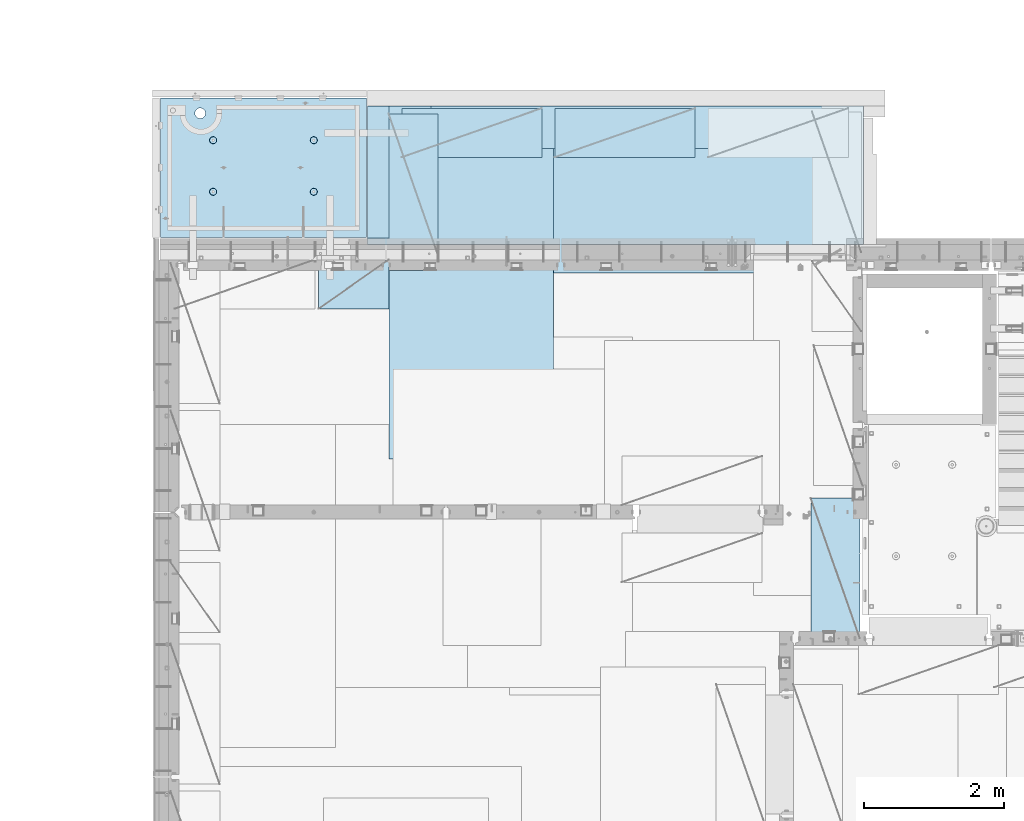
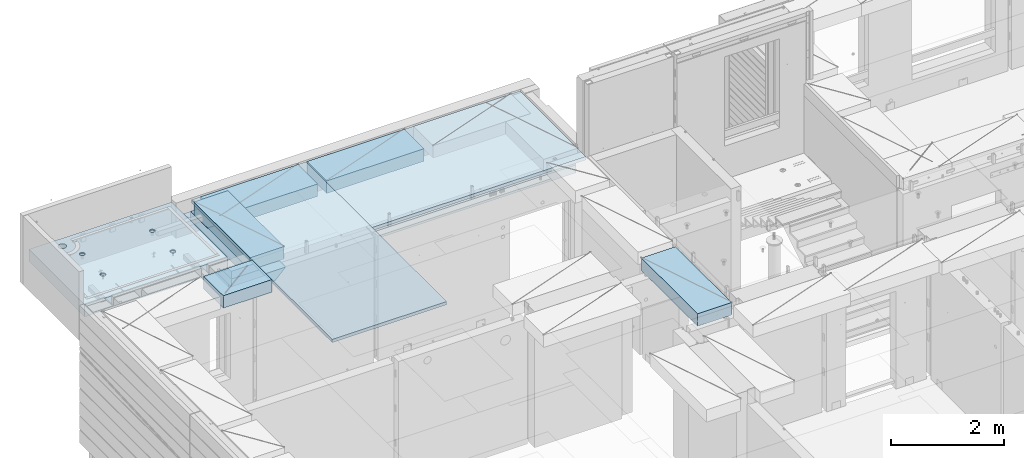
# One storey, part 185 of 325: 10 plates, 3 slabs, 13 elements without a shape of their own.
"""IFC2X3 building model written with IfcOpenShell, lengths in millimetres."""

from ifc_helpers import new_model, si_unit, frame, origin_with_axes, place, context, subcontext, project, spatial, faceted_brep, material, type_object, element, aggregate, save


model = new_model("IFC2X3")

# Units and contexts
model_context = context("Model", 3, precision=1e-05, world=origin_with_axes())
body_context = subcontext(model_context, "Body", "Model", "MODEL_VIEW")
ifc_project = project(units=[si_unit("LENGTHUNIT", "METRE", prefix="MILLI"), si_unit("AREAUNIT", "SQUARE_METRE"), si_unit("VOLUMEUNIT", "CUBIC_METRE"), si_unit("MASSUNIT", "GRAM", prefix="KILO"), si_unit("TIMEUNIT", "SECOND"), si_unit("PLANEANGLEUNIT", "RADIAN"), si_unit("SOLIDANGLEUNIT", "STERADIAN"), si_unit("THERMODYNAMICTEMPERATUREUNIT", "DEGREE_CELSIUS"), si_unit("LUMINOUSINTENSITYUNIT", "LUMEN")], contexts=[model_context])

# Site, building, storey
site_placement = place(None, origin_with_axes())
site = spatial("IfcSite", under=ifc_project, at=site_placement, CompositionType="ELEMENT")
building_placement = place(site_placement, origin_with_axes())
building = spatial("IfcBuilding", under=site, at=building_placement, CompositionType="ELEMENT")
storey_placement = place(building_placement, origin_with_axes())
storey = spatial("IfcBuildingStorey", under=building, at=storey_placement, Name="1", CompositionType="ELEMENT", Elevation=0.0)

# Assembly, slab
assembly_1_placement = place(storey_placement, origin_with_axes())
assembly_1 = element("IfcElementAssembly", 1, at=assembly_1_placement, inside=storey, AssemblyPlace="NOTDEFINED", PredefinedType="REINFORCEMENT_UNIT")
ifc_material_1 = material(Name="CONCRETE/C35/45")
slab_type_1 = type_object("IfcSlabType", PredefinedType="NOTDEFINED")
slab_1_placement = place(assembly_1_placement, frame((7734.99985681325, 20899.9965573523, 84575.0), z_axis=(-2.2639999995273e-06, 0.999999999997437, 0.0), x_axis=(0.999999999997251, 2.34499999952812e-06, 0.0)))
slab_1 = element("IfcSlab", 2, at=slab_1_placement, type_object=slab_type_1, material=ifc_material_1, PredefinedType="FLOOR", context=body_context, shape_type="Brep", body=[
    faceted_brep([(2200.45398600256, -110.0, 1337.44476079497), (2214.39241555253, -110.0, 1344.54670420538), (2225.45402859605, -110.0, 1355.60826537005), (2232.55603737762, -110.0, 1369.54666161175), (2235.0032477951, -110.0, 1384.99750559184), (2232.5561098421, -110.0, 1400.44836104917), (2225.45416643169, -110.0, 1414.38679059914), (2214.39260526702, -110.0, 1425.44840364265), (2200.45420902531, -110.0, 1432.55041242422), (2185.00336504523, -110.0, 1434.9976228417), (2169.55250958791, -110.0, 1432.55048488871), (2155.61408003793, -110.0, 1425.44854147829), (2144.55246699442, -110.0, 1414.38698031362), (2137.45045821285, -110.0, 1400.44858407192), (2135.00324779537, -110.0, 1384.99774009184), (2137.45038574836, -110.0, 1369.54688463451), (2144.55232915878, -110.0, 1355.60845508454), (2155.61389032345, -110.0, 1344.54684204102), (2169.55228656515, -110.0, 1337.44483325945), (2185.00313054523, -110.0, 1334.99762284198), (2226.41728354208, -130.0, 1415.08653268859), (2233.68832084322, -130.0, 1400.81623576839), (2215.09235187349, -130.0, 1426.41151747124), (2200.8220890546, -130.0, 1433.68262169999), (2185.0033678369, -130.0, 1436.18809903217), (2169.18463486868, -130.0, 1433.68269588982), (2154.91433794847, -130.0, 1426.41165858869), (2143.58935316583, -130.0, 1415.08672692009), (2136.31824893708, -130.0, 1400.81646410121), (2133.8127716049, -130.0, 1384.9977428835), (2136.31817474725, -130.0, 1369.17900991529), (2143.58921204838, -130.0, 1354.90871299508), (2154.91414371698, -130.0, 1343.58372821243), (2169.18440653586, -130.0, 1336.31262398369), (2185.00312775357, -130.0, 1333.8071466515), (2200.82186072178, -130.0, 1336.31254979386), (2215.09215764199, -130.0, 1343.58358709499), (2226.41714242464, -130.0, 1354.90851876358), (2233.68824665339, -130.0, 1369.17878158247), (2236.19372398557, -130.0, 1384.99750280017), (765.453986006505, -110.0, 1337.44812586997), (779.392415556478, -110.0, 1344.55006928038), (790.454028599992, -110.0, 1355.61163044505), (797.556037381562, -110.0, 1369.55002668675), (800.003247799041, -110.0, 1385.00087066684), (797.556109846048, -110.0, 1400.45172612417), (790.454166435635, -110.0, 1414.39015567414), (779.392605270965, -110.0, 1425.45176871765), (765.45420902926, -110.0, 1432.55377749922), (750.003365049179, -110.0, 1435.0009879167), (734.552509591851, -110.0, 1432.55384996371), (720.614080041878, -110.0, 1425.4519065533), (709.552466998364, -110.0, 1414.39034538862), (702.450458216794, -110.0, 1400.45194914692), (700.003247799315, -110.0, 1385.00110516684), (702.450385752309, -110.0, 1369.5502497095), (709.552329162721, -110.0, 1355.61182015954), (720.613890327391, -110.0, 1344.55020711602), (734.552286569096, -110.0, 1337.44819833446), (750.003130549179, -110.0, 1335.00098791698), (798.688320847163, -130.0, 1400.81960084339), (801.193723989514, -130.0, 1385.00086787517), (791.417283546027, -130.0, 1415.0898977636), (780.092351877434, -130.0, 1426.41488254624), (765.822089058547, -130.0, 1433.68598677499), (750.003367840845, -130.0, 1436.19146410717), (734.184634872629, -130.0, 1433.68606096482), (719.914337952418, -130.0, 1426.41502366369), (708.589353169771, -130.0, 1415.09009199509), (701.318248941023, -130.0, 1400.81982917621), (698.812771608842, -130.0, 1385.00110795851), (701.318174751194, -130.0, 1369.18237499029), (708.589212052329, -130.0, 1354.91207807008), (719.914143720922, -130.0, 1343.58709328743), (734.184406539811, -130.0, 1336.31598905868), (750.003127757513, -130.0, 1333.8105117265), (765.821860725729, -130.0, 1336.31591486885), (780.092157645939, -130.0, 1343.58695216999), (791.417142428585, -130.0, 1354.91188383858), (798.688246657333, -130.0, 1369.18214665747), (2935.0, -130.0, 1.16051523946226e-09), (0.0, -130.0, -3.63797880709171e-12), (0.0, 130.0, -1.81898940354586e-12), (2935.0, 130.0, 1.16051523946226e-09), (2935.00146484375, -130.0, 1985.00366210938), (2935.00146484375, 130.0, 1985.00366210938), (0.00127768016045593, -130.0, 1985.00366210937), (0.00127768016045593, 130.0, 1985.00366210937), (629.955082303701, 130.0, 1807.51685424544), (618.036222033796, 130.0, 1823.04989078421), (602.503241394663, 130.0, 1834.96882390392), (584.414687347387, 130.0, 1842.46139800945), (565.003264957546, 130.0, 1845.01700655756), (545.591830582116, 130.0, 1842.46148904905), (527.503241394868, 130.0, 1834.96899977892), (511.970204856105, 130.0, 1823.05013950902), (500.051271736391, 130.0, 1807.51715886988), (492.558697630866, 130.0, 1789.42860482261), (490.003089082753, 130.0, 1770.01718243277), (492.558606591267, 130.0, 1750.60574805734), (500.05109586139, 130.0, 1732.51715887009), (511.969956131295, 130.0, 1716.98412233133), (527.502936770432, 130.0, 1705.06518921161), (545.591490817707, 130.0, 1697.57261510608), (565.002913207545, 130.0, 1695.01700655797), (584.414347582979, 130.0, 1697.57252406649), (602.502936770226, 130.0, 1705.06501333661), (618.035973308986, 130.0, 1716.98387360652), (629.9549064287, 130.0, 1732.51685424565), (637.447480534229, 130.0, 1750.60540829293), (640.00308908234, 130.0, 1770.01683068277), (637.447571573828, 130.0, 1789.4282650582), (637.447571573828, -130.0, 1789.4282650582), (640.00308908234, -130.0, 1770.01683068277), (629.955082303701, -130.0, 1807.51685424544), (618.036222033796, -130.0, 1823.04989078421), (602.503241394663, -130.0, 1834.96882390392), (584.414687347387, -130.0, 1842.46139800945), (565.003264957546, -130.0, 1845.01700655756), (545.591830582116, -130.0, 1842.46148904905), (527.503241394868, -130.0, 1834.96899977892), (511.970204856105, -130.0, 1823.05013950902), (500.051271736391, -130.0, 1807.51715886988), (492.558697630866, -130.0, 1789.42860482261), (490.003089082753, -130.0, 1770.01718243277), (492.558606591267, -130.0, 1750.60574805734), (500.05109586139, -130.0, 1732.51715887009), (511.969956131295, -130.0, 1716.98412233133), (527.502936770432, -130.0, 1705.06518921161), (545.591490817707, -130.0, 1697.57261510608), (565.002913207545, -130.0, 1695.01700655797), (584.414347582979, -130.0, 1697.57252406649), (602.502936770226, -130.0, 1705.06501333661), (618.035973308986, -130.0, 1716.98387360652), (629.9549064287, -130.0, 1732.51685424565), (637.447480534229, -130.0, 1750.60540829293), (765.452262510529, -110.0, 602.446294854952), (779.390692060502, -110.0, 609.548238265361), (790.452305104016, -110.0, 620.609799430033), (797.554313885586, -110.0, 634.548195671738), (800.001524303065, -110.0, 649.999039651819), (797.554386350072, -110.0, 665.449895109152), (790.452442939657, -110.0, 679.388324659118), (779.390881774987, -110.0, 690.449937702637), (765.452485533282, -110.0, 697.551946484204), (750.001641553203, -110.0, 699.999156901682), (734.550786095873, -110.0, 697.552018948689), (720.6123565459, -110.0, 690.45007553828), (709.550743502386, -110.0, 679.388514373604), (702.448734720818, -110.0, 665.450118131903), (700.001524303339, -110.0, 649.999274151818), (702.448662256333, -110.0, 634.548418694489), (709.550605666745, -110.0, 620.609989144519), (720.612166831415, -110.0, 609.548376101004), (734.55056307312, -110.0, 602.446367319437), (750.001407053202, -110.0, 599.999156901958), (798.686597351187, -130.0, 665.817769828369), (801.192000493538, -130.0, 649.999036860154), (791.415560050051, -130.0, 680.088066748576), (780.090628381458, -130.0, 691.413051531228), (765.820365562571, -130.0, 698.684155759973), (750.001644344869, -130.0, 701.189633092159), (734.182911376653, -130.0, 698.684229949802), (719.912614456442, -130.0, 691.41319264867), (708.587629673795, -130.0, 680.088260980072), (701.316525445047, -130.0, 665.817998161187), (698.811048112866, -130.0, 649.999276943487), (701.316451255216, -130.0, 634.180543975268), (708.587488556352, -130.0, 619.910247055061), (719.912420224944, -130.0, 608.585262272412), (734.182683043833, -130.0, 601.314158043664), (750.001404261535, -130.0, 598.808680711485), (765.820137229752, -130.0, 601.314083853835), (780.090434149961, -130.0, 608.585121154971), (791.415418932607, -130.0, 619.910052823565), (798.686523161356, -130.0, 634.18031564245), (2200.45226250658, -110.0, 602.442929779951), (2214.39069205656, -110.0, 609.544873190363), (2225.45230510007, -110.0, 620.606434355035), (2232.55431388164, -110.0, 634.544830596737), (2235.00152429912, -110.0, 649.995674576818), (2232.55438634613, -110.0, 665.446530034151), (2225.45244293571, -110.0, 679.38495958412), (2214.39088177104, -110.0, 690.446572627639), (2200.45248552934, -110.0, 697.548581409203), (2185.00164154926, -110.0, 699.995791826681), (2169.55078609193, -110.0, 697.548653873688), (2155.61235654195, -110.0, 690.446710463279), (2144.55074349844, -110.0, 679.385149298603), (2137.44873471687, -110.0, 665.446753056905), (2135.00152429939, -110.0, 649.995909076821), (2137.44866225239, -110.0, 634.545053619491), (2144.5506056628, -110.0, 620.606624069518), (2155.61216682747, -110.0, 609.545011026003), (2169.55056306918, -110.0, 602.443002244436), (2185.00140704926, -110.0, 599.995791826957), (2233.68659734724, -130.0, 665.814404753368), (2236.19200048959, -130.0, 649.995671785153), (2226.41556004611, -130.0, 680.084701673575), (2215.09062837751, -130.0, 691.409686456227), (2200.82036555863, -130.0, 698.680790684972), (2185.00164434092, -130.0, 701.186268017158), (2169.18291137271, -130.0, 698.680864874805), (2154.9126144525, -130.0, 691.409827573672), (2143.58762966985, -130.0, 680.084895905075), (2136.3165254411, -130.0, 665.814633086189), (2133.81104810892, -130.0, 649.995911868486), (2136.31645125127, -130.0, 634.177178900271), (2143.58748855241, -130.0, 619.906881980063), (2154.912420221, -130.0, 608.581897197415), (2169.18268303989, -130.0, 601.310792968667), (2185.00140425759, -130.0, 598.805315636484), (2200.82013722581, -130.0, 601.310718778834), (2215.09043414602, -130.0, 608.58175607997), (2226.41541892866, -130.0, 619.906687748564), (2233.68652315741, -130.0, 634.176950567449)], [[[0, 1, 2, 3, 4, 5, 6, 7, 8, 9, 10, 11, 12, 13, 14, 15, 16, 17, 18, 19]], [[20, 6, 5, 21]], [[22, 7, 6, 20]], [[23, 8, 7, 22]], [[24, 9, 8, 23]], [[25, 10, 9, 24]], [[26, 11, 10, 25]], [[27, 12, 11, 26]], [[28, 13, 12, 27]], [[29, 14, 13, 28]], [[30, 15, 14, 29]], [[31, 16, 15, 30]], [[32, 17, 16, 31]], [[33, 18, 17, 32]], [[34, 19, 18, 33]], [[35, 0, 19, 34]], [[36, 1, 0, 35]], [[37, 2, 1, 36]], [[38, 3, 2, 37]], [[39, 4, 3, 38]], [[21, 5, 4, 39]], [[40, 41, 42, 43, 44, 45, 46, 47, 48, 49, 50, 51, 52, 53, 54, 55, 56, 57, 58, 59]], [[60, 45, 44, 61]], [[62, 46, 45, 60]], [[63, 47, 46, 62]], [[64, 48, 47, 63]], [[65, 49, 48, 64]], [[66, 50, 49, 65]], [[67, 51, 50, 66]], [[68, 52, 51, 67]], [[69, 53, 52, 68]], [[70, 54, 53, 69]], [[71, 55, 54, 70]], [[72, 56, 55, 71]], [[73, 57, 56, 72]], [[74, 58, 57, 73]], [[75, 59, 58, 74]], [[76, 40, 59, 75]], [[77, 41, 40, 76]], [[78, 42, 41, 77]], [[79, 43, 42, 78]], [[61, 44, 43, 79]], [[80, 81, 82, 83]], [[84, 80, 83, 85]], [[86, 84, 85, 87]], [[81, 86, 87, 82]], [[85, 83, 82, 87], [88, 89, 90, 91, 92, 93, 94, 95, 96, 97, 98, 99, 100, 101, 102, 103, 104, 105, 106, 107, 108, 109, 110, 111]], [[112, 111, 110, 113]], [[114, 88, 111, 112]], [[115, 89, 88, 114]], [[116, 90, 89, 115]], [[117, 91, 90, 116]], [[118, 92, 91, 117]], [[119, 93, 92, 118]], [[120, 94, 93, 119]], [[121, 95, 94, 120]], [[122, 96, 95, 121]], [[123, 97, 96, 122]], [[124, 98, 97, 123]], [[125, 99, 98, 124]], [[126, 100, 99, 125]], [[127, 101, 100, 126]], [[128, 102, 101, 127]], [[129, 103, 102, 128]], [[130, 104, 103, 129]], [[131, 105, 104, 130]], [[132, 106, 105, 131]], [[133, 107, 106, 132]], [[134, 108, 107, 133]], [[135, 109, 108, 134]], [[113, 110, 109, 135]], [[136, 137, 138, 139, 140, 141, 142, 143, 144, 145, 146, 147, 148, 149, 150, 151, 152, 153, 154, 155]], [[156, 141, 140, 157]], [[158, 142, 141, 156]], [[159, 143, 142, 158]], [[160, 144, 143, 159]], [[161, 145, 144, 160]], [[162, 146, 145, 161]], [[163, 147, 146, 162]], [[164, 148, 147, 163]], [[165, 149, 148, 164]], [[166, 150, 149, 165]], [[167, 151, 150, 166]], [[168, 152, 151, 167]], [[169, 153, 152, 168]], [[170, 154, 153, 169]], [[171, 155, 154, 170]], [[172, 136, 155, 171]], [[173, 137, 136, 172]], [[174, 138, 137, 173]], [[175, 139, 138, 174]], [[157, 140, 139, 175]], [[176, 177, 178, 179, 180, 181, 182, 183, 184, 185, 186, 187, 188, 189, 190, 191, 192, 193, 194, 195]], [[196, 181, 180, 197]], [[198, 182, 181, 196]], [[199, 183, 182, 198]], [[200, 184, 183, 199]], [[201, 185, 184, 200]], [[202, 186, 185, 201]], [[203, 187, 186, 202]], [[204, 188, 187, 203]], [[205, 189, 188, 204]], [[206, 190, 189, 205]], [[207, 191, 190, 206]], [[208, 192, 191, 207]], [[209, 193, 192, 208]], [[210, 194, 193, 209]], [[211, 195, 194, 210]], [[212, 176, 195, 211]], [[213, 177, 176, 212]], [[214, 178, 177, 213]], [[215, 179, 178, 214]], [[197, 180, 179, 215]], [[80, 84, 86, 81], [37, 36, 35, 34, 33, 32, 31, 30, 29, 28, 27, 26, 25, 24, 23, 22, 20, 21, 39, 38], [214, 213, 212, 211, 210, 209, 208, 207, 206, 205, 204, 203, 202, 201, 200, 199, 198, 196, 197, 215], [174, 173, 172, 171, 170, 169, 168, 167, 166, 165, 164, 163, 162, 161, 160, 159, 158, 156, 157, 175], [134, 133, 132, 131, 130, 129, 128, 127, 126, 125, 124, 123, 122, 121, 120, 119, 118, 117, 116, 115, 114, 112, 113, 135], [78, 77, 76, 75, 74, 73, 72, 71, 70, 69, 68, 67, 66, 65, 64, 63, 62, 60, 61, 79]]]),
])
aggregate(assembly_1, [slab_1])

assembly_2_placement = place(storey_placement, origin_with_axes())
assembly_2 = element("IfcElementAssembly", 3, at=assembly_2_placement, inside=storey, AssemblyPlace="NOTDEFINED", PredefinedType="REINFORCEMENT_UNIT")
ifc_material_2 = material(Name="CONCRETE/C30/37")
slab_type_2 = type_object("IfcSlabType", PredefinedType="NOTDEFINED")
slab_2_placement = place(assembly_2_placement, frame((10989.9998325205, 22770.0000000013, 84350.0), z_axis=(1.0, 0.0, 0.0), x_axis=(0.0, -1.0, 0.0)))
slab_2 = element("IfcSlab", 4, at=slab_2_placement, type_object=slab_type_2, material=ifc_material_2, PredefinedType="FLOOR", context=body_context, shape_type="Brep", body=[
    faceted_brep([(2339.998046875, 110.0, 0.0), (0.0, 110.0, 0.0), (2339.998046875, 110.0, 380.0), (0.0, 110.0, 380.0), (2339.998046875, -109.669999999998, 600.0), (1.81898940354586e-12, -110.000000000058, 0.0), (0.0, -110.0, 380.0), (0.0, -110.0, 600.0), (0.0, -109.669999999998, 600.0), (2339.998046875, -110.0, 600.0), (2339.998046875, -110.0, 380.0), (2339.998046875, -110.0, 0.0)], [[[0, 1, 2]], [[3, 2, 1]], [[4, 2, 3]], [[5, 6, 3, 1]], [[6, 7, 8, 3]], [[7, 9, 4, 8]], [[9, 10, 2, 4]], [[10, 11, 0, 2]], [[11, 5, 1, 0]], [[8, 4, 3]], [[11, 10, 9, 7, 6, 5]]]),
])
aggregate(assembly_2, [slab_2])

assembly_3_placement = place(storey_placement, origin_with_axes())
assembly_3 = element("IfcElementAssembly", 5, at=assembly_3_placement, inside=storey, AssemblyPlace="NOTDEFINED", PredefinedType="REINFORCEMENT_UNIT")
slab_3_placement = place(assembly_3_placement, frame((17760.0000000013, 22770.0001674795, 84350.0), z_axis=(0.0, -1.0, 0.0), x_axis=(-1.0, 3.00000001838171e-08, 0.0)))
slab_3 = element("IfcSlab", 6, at=slab_3_placement, type_object=slab_type_2, material=ifc_material_2, PredefinedType="FLOOR", context=body_context, shape_type="Brep", body=[
    faceted_brep([(6769.998046875, 110.0, 0.0), (0.0, 110.0, 0.0), (6769.998046875, 110.0, 380.0), (0.0, 110.0, 380.0), (6769.998046875, -109.669999999998, 600.0), (1.81898940354586e-12, -110.000000000058, 0.0), (0.0, -110.0, 380.0), (0.0, -110.0, 600.0), (0.0, -109.669999999998, 600.0), (6769.998046875, -110.0, 600.0), (6769.998046875, -110.0, 380.0), (6769.998046875, -110.0, 0.0)], [[[0, 1, 2]], [[3, 2, 1]], [[4, 2, 3]], [[5, 6, 3, 1]], [[6, 7, 8, 3]], [[7, 9, 4, 8]], [[9, 10, 2, 4]], [[10, 11, 0, 2]], [[11, 5, 1, 0]], [[8, 4, 3]], [[11, 10, 9, 7, 6, 5]]]),
])
aggregate(assembly_3, [slab_3])

# Assembly, plate
assembly_4_placement = place(storey_placement, origin_with_axes())
assembly_4 = element("IfcElementAssembly", 7, at=assembly_4_placement, inside=storey, Name="Steel Assembly", AssemblyPlace="NOTDEFINED", PredefinedType="NOTDEFINED")
ifc_material_3 = material(Name="EPS")
plate_type_1 = type_object("IfcPlateType", PredefinedType="NOTDEFINED")
plate_1_placement = place(assembly_4_placement, frame((10685.0002441406, 22770.0, 84086.0), z_axis=(1.0, 0.0, 0.0), x_axis=(0.0, -1.0, 0.0)))
plate_1 = element("IfcPlate", 8, at=plate_1_placement, type_object=plate_type_1, material=ifc_material_3, context=body_context, shape_type="Brep", body=[
    faceted_brep([(0.0, -35.0, 0.0), (0.0, -35.0, 7075.0), (0.0, 35.0, 7075.0), (0.0, 35.0, 0.0), (1880.00476074219, -35.0, 7075.0), (1880.00476074219, 35.0, 7075.0), (1880.00476074219, -35.0, 0.0), (1880.00476074219, 35.0, 0.0)], [[[0, 1, 2, 3]], [[1, 4, 5, 2]], [[4, 6, 7, 5]], [[6, 0, 3, 7]], [[5, 7, 3, 2]], [[6, 4, 1, 0]]]),
])
aggregate(assembly_4, [plate_1])

assembly_5_placement = place(storey_placement, origin_with_axes())
assembly_5 = element("IfcElementAssembly", 9, at=assembly_5_placement, inside=storey, Name="Steel Assembly", AssemblyPlace="NOTDEFINED", PredefinedType="NOTDEFINED")
plate_type_2 = type_object("IfcPlateType", PredefinedType="NOTDEFINED")
plate_2_placement = place(assembly_5_placement, frame((10685.0002441406, 22770.0, 84206.0), z_axis=(1.0, 0.0, 0.0), x_axis=(0.0, -1.0, 0.0)))
plate_2 = element("IfcPlate", 10, at=plate_2_placement, type_object=plate_type_2, material=ifc_material_3, context=body_context, shape_type="Brep", body=[
    faceted_brep([(1970.00476074219, -85.0, 7075.0), (1970.00476074219, -85.0, 0.0), (1970.00476074219, 85.0, 0.0), (1970.00476074219, 85.0, 7075.0), (0.0, -85.0, 7075.0), (0.0, 85.0, 7075.0), (0.0, -85.0, 0.0), (0.0, 85.0, 0.0), (1895.00481277243, 53.5, 2762.49975585938), (1885.00481277243, 51.5, 2762.49975585938), (1885.00481277243, 51.5, 6822.49975585938), (1895.00481277243, 53.5, 6822.49975585938), (1895.00481277243, 63.5, 2762.49975585938), (1895.00481277243, 63.5, 6822.49975585938), (1885.00481277243, 65.5, 2762.49975585938), (1885.00481277243, 65.5, 6822.49975585938)], [[[0, 1, 2, 3]], [[4, 0, 3, 5]], [[1, 0, 4, 6]], [[1, 6, 7, 2]], [[3, 2, 7, 5]], [[6, 4, 5, 7]], [[8, 9, 10, 11]], [[12, 8, 11, 13]], [[9, 8, 12, 14]], [[9, 14, 15, 10]], [[11, 10, 15, 13]], [[14, 12, 13, 15]]]),
])
aggregate(assembly_5, [plate_2])

assembly_6_placement = place(storey_placement, origin_with_axes())
assembly_6 = element("IfcElementAssembly", 11, at=assembly_6_placement, inside=storey, Name="Steel Assembly", AssemblyPlace="NOTDEFINED", PredefinedType="NOTDEFINED")
plate_3_placement = place(assembly_6_placement, frame((10685.0002441406, 22770.0, 84375.0), z_axis=(1.0, 0.0, 0.0), x_axis=(0.0, -1.0, 0.0)))
plate_3 = element("IfcPlate", 12, at=plate_3_placement, type_object=plate_type_2, material=ifc_material_3, context=body_context, shape_type="Brep", body=[
    faceted_brep([(0.0, -85.0, 0.0), (0.0, -85.0, 7075.0), (0.0, 85.0, 7075.0), (0.0, 85.0, 0.0), (1970.00476074219, -85.0, 7075.0), (1970.00476074219, 85.0, 7075.0), (1970.00476074219, -85.0, 0.0), (1970.00476074219, 85.0, 0.0)], [[[0, 1, 2, 3]], [[1, 4, 5, 2]], [[4, 6, 7, 5]], [[6, 0, 3, 7]], [[5, 7, 3, 2]], [[6, 4, 1, 0]]]),
])
aggregate(assembly_6, [plate_3])

assembly_7_placement = place(storey_placement, origin_with_axes())
assembly_7 = element("IfcElementAssembly", 13, at=assembly_7_placement, inside=storey, Name="Steel Assembly", AssemblyPlace="NOTDEFINED", PredefinedType="NOTDEFINED")
ifc_material_4 = material()
plate_type_3 = type_object("IfcPlateType", PredefinedType="NOTDEFINED")
plate_4_placement = place(assembly_7_placement, frame((12729.9998779297, 22740.0009765625, 84695.1), z_axis=(1.0, 0.0, 0.0), x_axis=(0.0, -1.0, 0.0)))
plate_4 = element("IfcPlate", 14, at=plate_4_placement, type_object=plate_type_3, material=ifc_material_4, context=body_context, shape_type="Brep", body=[
    faceted_brep([(0.0, -35.0, 0.0), (0.0, -35.0, 5000.0), (0.0, 35.0, 5000.0), (0.0, 35.0, 0.0), (2349.99951171875, -35.0, 5000.0), (2349.99951171875, 35.0, 5000.0), (2350.0, -35.0, 0.0), (2350.0, 35.0, 0.0)], [[[0, 1, 2, 3]], [[1, 4, 5, 2]], [[4, 6, 7, 5]], [[6, 0, 3, 7]], [[5, 7, 3, 2]], [[6, 4, 1, 0]]]),
])
aggregate(assembly_7, [plate_4])

assembly_8_placement = place(storey_placement, origin_with_axes())
assembly_8 = element("IfcElementAssembly", 15, at=assembly_8_placement, inside=storey, Name="Steel Assembly", AssemblyPlace="NOTDEFINED", PredefinedType="NOTDEFINED")
plate_5_placement = place(assembly_8_placement, frame((13340.0, 22740.0, 84695.1), z_axis=(0.0, -1.0, 0.0), x_axis=(-1.0, 3.00000001838171e-08, 0.0)))
plate_5 = element("IfcPlate", 16, at=plate_5_placement, type_object=plate_type_3, material=ifc_material_4, context=body_context, shape_type="Brep", body=[
    faceted_brep([(0.0, -35.0, 0.0), (0.0, -35.0, 5000.0), (0.0, 35.0, 5000.0), (0.0, 35.0, 0.0), (2349.99951171875, -35.0, 5000.0), (2349.99951171875, 35.0, 5000.0), (2350.0, -35.0, 0.0), (2350.0, 35.0, 0.0)], [[[0, 1, 2, 3]], [[1, 4, 5, 2]], [[4, 6, 7, 5]], [[6, 0, 3, 7]], [[5, 7, 3, 2]], [[6, 4, 1, 0]]]),
])
aggregate(assembly_8, [plate_5])

assembly_9_placement = place(storey_placement, origin_with_axes())
assembly_9 = element("IfcElementAssembly", 17, at=assembly_9_placement, inside=storey, Name="Steel Assembly", AssemblyPlace="NOTDEFINED", PredefinedType="NOTDEFINED")
plate_type_4 = type_object("IfcPlateType", PredefinedType="NOTDEFINED")
plate_6_placement = place(assembly_9_placement, frame((17710.0001220703, 15180.0, 84595.3), z_axis=(-1.0, 3.00000001838171e-08, 0.0), x_axis=(0.0, 1.0, 0.0)))
plate_6 = element("IfcPlate", 18, at=plate_6_placement, type_object=plate_type_4, material=ifc_material_4, Name="RE1", context=body_context, shape_type="Brep", body=[
    faceted_brep([(1.81898940354586e-12, -135.0, 1.81898940354586e-12), (0.0, -135.0, 699.999999999996), (0.0, 135.0, 699.999999999996), (1.81898940354586e-12, 135.0, 1.81898940354586e-12), (1999.99951171875, -135.0, 699.999999999993), (1999.99951171875, 135.0, 699.999999999993), (2000.0, -135.0, -3.63797880709171e-12), (2000.0, 135.0, -3.63797880709171e-12)], [[[0, 1, 2, 3]], [[1, 4, 5, 2]], [[4, 6, 7, 5]], [[6, 0, 3, 7]], [[5, 7, 3, 2]], [[6, 4, 1, 0]]]),
])
aggregate(assembly_9, [plate_6])

assembly_10_placement = place(storey_placement, origin_with_axes())
assembly_10 = element("IfcElementAssembly", 19, at=assembly_10_placement, inside=storey, Name="Steel Assembly", AssemblyPlace="NOTDEFINED", PredefinedType="NOTDEFINED")
plate_7_placement = place(assembly_10_placement, frame((13175.0, 22740.0001220703, 84595.3), z_axis=(0.0, -1.0, 0.0), x_axis=(-1.0, 3.00000001838171e-08, 0.0)))
plate_7 = element("IfcPlate", 20, at=plate_7_placement, type_object=plate_type_4, material=ifc_material_4, Name="RE1", context=body_context, shape_type="Brep", body=[
    faceted_brep([(1.81898940354586e-12, -135.0, 1.81898940354586e-12), (0.0, -135.0, 699.999999999996), (0.0, 135.0, 699.999999999996), (1.81898940354586e-12, 135.0, 1.81898940354586e-12), (1999.99951171875, -135.0, 699.999999999993), (1999.99951171875, 135.0, 699.999999999993), (2000.0, -135.0, -3.63797880709171e-12), (2000.0, 135.0, -3.63797880709171e-12)], [[[0, 1, 2, 3]], [[1, 4, 5, 2]], [[4, 6, 7, 5]], [[6, 0, 3, 7]], [[5, 7, 3, 2]], [[6, 4, 1, 0]]]),
])
aggregate(assembly_10, [plate_7])

assembly_11_placement = place(storey_placement, origin_with_axes())
assembly_11 = element("IfcElementAssembly", 21, at=assembly_11_placement, inside=storey, Name="Steel Assembly", AssemblyPlace="NOTDEFINED", PredefinedType="NOTDEFINED")
plate_8_placement = place(assembly_11_placement, frame((15360.0, 22740.0001220703, 84595.3), z_axis=(0.0, -1.0, 0.0), x_axis=(-1.0, 3.00000001838171e-08, 0.0)))
plate_8 = element("IfcPlate", 22, at=plate_8_placement, type_object=plate_type_4, material=ifc_material_4, Name="RE1", context=body_context, shape_type="Brep", body=[
    faceted_brep([(1.81898940354586e-12, -135.0, 1.81898940354586e-12), (0.0, -135.0, 699.999999999996), (0.0, 135.0, 699.999999999996), (1.81898940354586e-12, 135.0, 1.81898940354586e-12), (1999.99951171875, -135.0, 699.999999999993), (1999.99951171875, 135.0, 699.999999999993), (2000.0, -135.0, -3.63797880709171e-12), (2000.0, 135.0, -3.63797880709171e-12)], [[[0, 1, 2, 3]], [[1, 4, 5, 2]], [[4, 6, 7, 5]], [[6, 0, 3, 7]], [[5, 7, 3, 2]], [[6, 4, 1, 0]]]),
])
aggregate(assembly_11, [plate_8])

assembly_12_placement = place(storey_placement, origin_with_axes())
assembly_12 = element("IfcElementAssembly", 23, at=assembly_12_placement, inside=storey, Name="Steel Assembly", AssemblyPlace="NOTDEFINED", PredefinedType="NOTDEFINED")
plate_9_placement = place(assembly_12_placement, frame((10989.9998779297, 22660.0, 84595.3), z_axis=(1.0, 0.0, 0.0), x_axis=(0.0, -1.0, 0.0)))
plate_9 = element("IfcPlate", 24, at=plate_9_placement, type_object=plate_type_4, material=ifc_material_4, Name="RE1", context=body_context, shape_type="Brep", body=[
    faceted_brep([(1.81898940354586e-12, -135.0, 1.81898940354586e-12), (0.0, -135.0, 699.999999999996), (0.0, 135.0, 699.999999999996), (1.81898940354586e-12, 135.0, 1.81898940354586e-12), (1999.99951171875, -135.0, 699.999999999993), (1999.99951171875, 135.0, 699.999999999993), (2000.0, -135.0, -3.63797880709171e-12), (2000.0, 135.0, -3.63797880709171e-12)], [[[0, 1, 2, 3]], [[1, 4, 5, 2]], [[4, 6, 7, 5]], [[6, 0, 3, 7]], [[5, 7, 3, 2]], [[6, 4, 1, 0]]]),
])
aggregate(assembly_12, [plate_9])

assembly_13_placement = place(storey_placement, origin_with_axes())
assembly_13 = element("IfcElementAssembly", 25, at=assembly_13_placement, inside=storey, Name="Steel Assembly", AssemblyPlace="NOTDEFINED", PredefinedType="NOTDEFINED")
plate_10_placement = place(assembly_13_placement, frame((10990.0, 20580.0000000707, 84595.3), z_axis=(0.0, -1.0, 0.0), x_axis=(-1.0, 3.00000001838171e-08, 0.0)))
plate_10 = element("IfcPlate", 26, at=plate_10_placement, type_object=plate_type_4, material=ifc_material_4, Name="RE1_1/2", context=body_context, shape_type="Brep", body=[
    faceted_brep([(1.81898940354586e-12, -135.0, 1.81898940354586e-12), (0.0, -135.0, 699.999999999996), (0.0, 135.0, 699.999999999996), (1.81898940354586e-12, 135.0, 1.81898940354586e-12), (999.99951171875, -135.0, 700.0), (999.99951171875, 135.0, 700.0), (1000.0, -135.0, 0.0), (1000.0, 135.0, 0.0)], [[[0, 1, 2, 3]], [[1, 4, 5, 2]], [[4, 6, 7, 5]], [[6, 0, 3, 7]], [[5, 7, 3, 2]], [[6, 4, 1, 0]]]),
])
aggregate(assembly_13, [plate_10])

save(model, "model.ifc")
